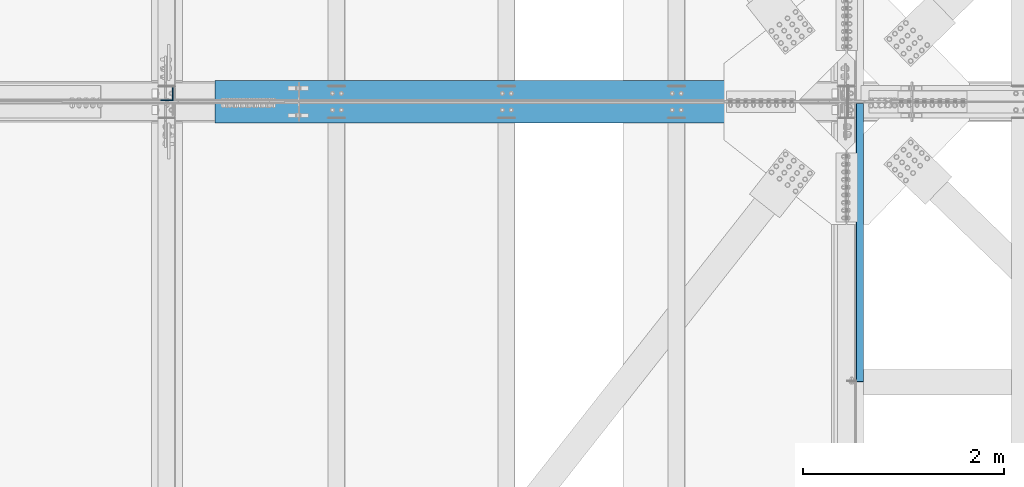
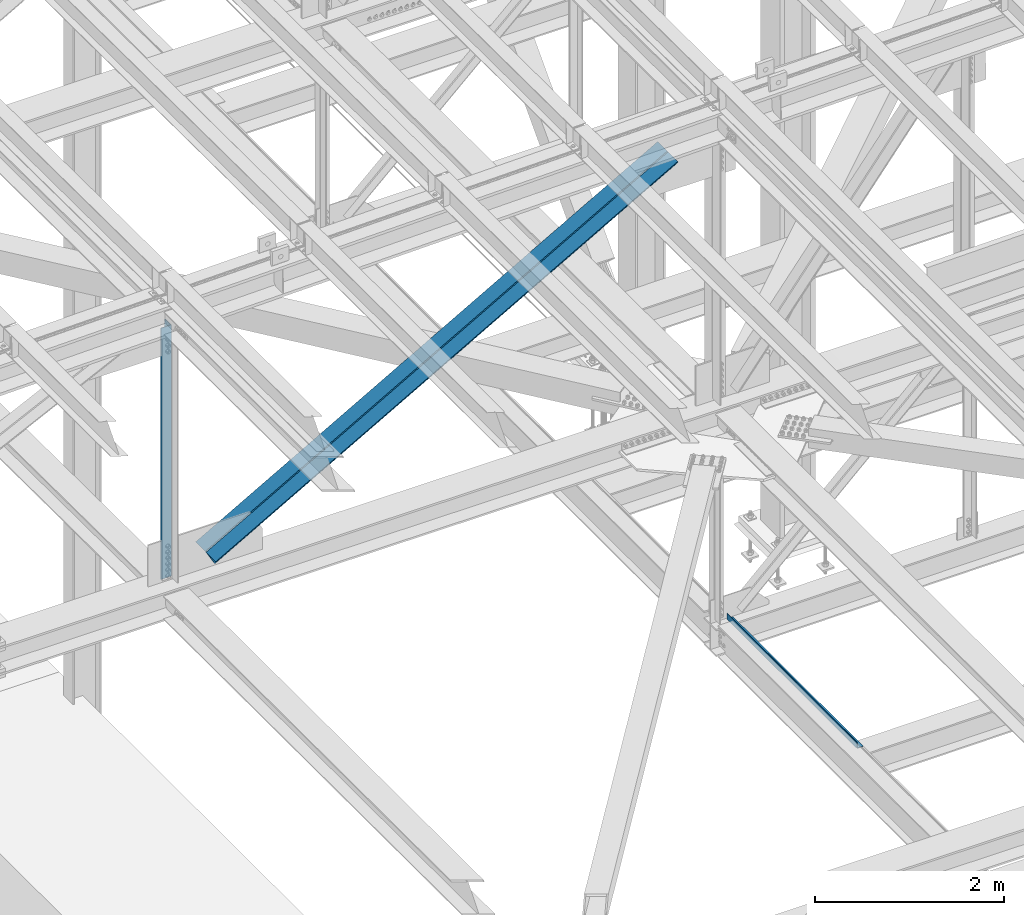
# One storey, part 1905 of 3843: 2 beams, 2 members, 4 elements without a shape of their own.
"""IFC2X3 building model written with IfcOpenShell, lengths in millimetres."""

from ifc_helpers import new_model, si_unit, frame, origin_with_axes, place, context, subcontext, project, spatial, faceted_brep, material, type_object, element, aggregate, save


model = new_model("IFC2X3")

# Units and contexts
model_context = context("Model", 3, precision=1e-05, world=origin_with_axes())
body_context = subcontext(model_context, "Body", "Model", "MODEL_VIEW")
ifc_project = project(units=[si_unit("LENGTHUNIT", "METRE", prefix="MILLI"), si_unit("AREAUNIT", "SQUARE_METRE"), si_unit("VOLUMEUNIT", "CUBIC_METRE"), si_unit("MASSUNIT", "GRAM", prefix="KILO"), si_unit("TIMEUNIT", "SECOND"), si_unit("PLANEANGLEUNIT", "RADIAN"), si_unit("SOLIDANGLEUNIT", "STERADIAN"), si_unit("THERMODYNAMICTEMPERATUREUNIT", "DEGREE_CELSIUS"), si_unit("LUMINOUSINTENSITYUNIT", "LUMEN")], contexts=[model_context])

# Site, building, storey
site_placement = place(None, origin_with_axes())
site = spatial("IfcSite", under=ifc_project, at=site_placement, CompositionType="ELEMENT")
building_placement = place(site_placement, origin_with_axes())
building = spatial("IfcBuilding", under=site, at=building_placement, Name="Undefined", CompositionType="ELEMENT")
storey_placement = place(building_placement, origin_with_axes())
storey = spatial("IfcBuildingStorey", under=building, at=storey_placement, Name="Undefined", CompositionType="ELEMENT", Elevation=0.0)

# Assembly, beam
assembly_1_placement = place(storey_placement, origin_with_axes())
assembly_1 = element("IfcElementAssembly", 1, at=assembly_1_placement, inside=storey, Name="BENT_PLATE", AssemblyPlace="NOTDEFINED", PredefinedType="RIGID_FRAME")
ifc_material_1 = material(Name="STEEL/A36")
beam_type_1 = type_object("IfcBeamType", PredefinedType="NOTDEFINED")
beam_1_placement = place(assembly_1_placement, frame((77179.4875000009, 74225.94475, 39627.1749999995), z_axis=(0.0, 1.0, 0.0), x_axis=(-1.0, 0.0, 0.0)))
beam_1 = element("IfcBeam", 2, at=beam_1_placement, type_object=beam_type_1, material=ifc_material_1, Name="BENT_PLATE", context=body_context, shape_type="Brep", body=[
    faceted_brep([(69.8500000005442, 3.17500000000291, -1379.53750006141), (73.0249999379594, 0.00100003396073589, -1382.71249999999), (0.0, 0.00100003396073589, -1382.71249999999), (0.0, 3.17500000000291, -1379.53850000001), (69.850000000617, 73.0249999994776, -1379.53750006141), (73.02500000078, 73.0249999994703, -1382.71249999999), (0.0, 3.17500000000291, 1382.71249999999), (69.8500000005442, 3.17500000000291, 1382.71249999999), (0.0, -3.17500000000291, -1382.71249999999), (0.0, -3.17500000000291, 1382.71249999999), (76.2000000005355, -3.17500000000291, -1382.71249999999), (76.2000000005355, -3.17500000000291, 1382.71249999999), (69.850000000617, 73.0249999994776, 1382.71249999999), (76.2000000006228, 73.024999999463, 1382.71249999999), (76.2000000006228, 73.024999999463, -1382.71249999999)], [[[0, 1, 2, 3]], [[4, 5, 1, 0]], [[6, 7, 0, 3]], [[8, 9, 6, 3, 2]], [[9, 8, 10, 11]], [[7, 12, 4, 0]], [[7, 6, 9, 11, 13, 12]], [[11, 10, 14, 13]], [[5, 14, 10, 8, 2, 1]], [[12, 13, 14, 5, 4]]]),
])
aggregate(assembly_1, [beam_1])

assembly_2_placement = place(storey_placement, origin_with_axes())
assembly_2 = element("IfcElementAssembly", 3, at=assembly_2_placement, inside=storey, Name="ANGLE", AssemblyPlace="NOTDEFINED", PredefinedType="RIGID_FRAME")
ifc_material_2 = material(Name="STEEL/A572-50")
beam_type_2 = type_object("IfcBeamType", Name="L5X5X3/8", PredefinedType="NOTDEFINED")
beam_2_placement = place(assembly_2_placement, frame((70256.4000000248, 75701.525, 46014.1431761409), z_axis=(-1.0, 0.0, 0.0), x_axis=(0.0, 0.0, -1.0)))
beam_2 = element("IfcBeam", 4, at=beam_2_placement, type_object=beam_type_2, material=ifc_material_2, Name="ANGLE", ObjectType="L5X5X3/8", context=body_context, shape_type="Brep", body=[
    faceted_brep([(223.220310098804, 63.5, -63.5), (223.220310098804, 63.5, 63.5), (3476.5794706795, 63.5, 63.5), (3476.5794706795, 63.5, -63.5), (223.220310098804, 53.9750000000058, 63.5), (3476.5794706795, 53.9750000000058, 63.5), (223.220310098804, 53.9750000000058, -53.9750000000058), (3476.5794706795, 53.9750000000058, -53.9750000000058), (223.220310098804, -63.5, -53.9750000000058), (3476.5794706795, -63.5, -53.9750000000058), (223.220310098804, -63.5, -63.5), (3476.5794706795, -63.5, -63.5)], [[[0, 1, 2, 3]], [[1, 4, 5, 2]], [[4, 6, 7, 5]], [[6, 8, 9, 7]], [[8, 10, 11, 9]], [[10, 0, 3, 11]], [[5, 7, 9, 11, 3, 2]], [[10, 8, 6, 4, 1, 0]]]),
])
aggregate(assembly_2, [beam_2])

# Assembly, member
assembly_3_placement = place(storey_placement, origin_with_axes())
assembly_3 = element("IfcElementAssembly", 5, at=assembly_3_placement, inside=storey, Name="ANGLE", AssemblyPlace="NOTDEFINED", PredefinedType="RIGID_FRAME")
member_type = type_object("IfcMemberType", Name="L8X8X1/2", PredefinedType="NOTDEFINED")
member_1_placement = place(assembly_3_placement, frame((77012.8000011244, 75739.625, 46150.0389029205), z_axis=(0.0, 1.0, 0.0), x_axis=(-0.870312627855801, 0.0, -0.492499674918401)))
member_1 = element("IfcMember", 6, at=member_1_placement, type_object=member_type, material=ifc_material_2, Name="ANGLE", ObjectType="L8X8X1/2", context=body_context, shape_type="Brep", body=[
    faceted_brep([(655.764717872153, 101.60000000042, -101.600000000006), (655.764717872153, 101.60000000042, 101.600000000006), (7157.46080485564, 101.600000004677, 101.600000000006), (7157.46080485564, 101.600000004677, -101.600000000006), (655.764717872153, 88.9000000004303, 101.600000000006), (7157.46080485564, 88.9000000046794, 101.600000000006), (655.764717872153, 88.9000000004303, -88.8999999999942), (7157.46080485564, 88.9000000046794, -88.8999999999942), (655.764717872138, -101.599999999555, -88.8999999999942), (7157.46080485564, -101.599999995306, -88.8999999999942), (655.764717872138, -101.599999999555, -101.600000000006), (7157.46080485564, -101.599999995306, -101.600000000006)], [[[0, 1, 2, 3]], [[1, 4, 5, 2]], [[4, 6, 7, 5]], [[6, 8, 9, 7]], [[8, 10, 11, 9]], [[10, 0, 3, 11]], [[5, 7, 9, 11, 3, 2]], [[10, 8, 6, 4, 1, 0]]]),
])
aggregate(assembly_3, [member_1])

assembly_4_placement = place(storey_placement, origin_with_axes())
assembly_4 = element("IfcElementAssembly", 7, at=assembly_4_placement, inside=storey, Name="ANGLE", AssemblyPlace="NOTDEFINED", PredefinedType="RIGID_FRAME")
member_2_placement = place(assembly_4_placement, frame((70256.4, 75517.375, 42326.6716433361), z_axis=(0.0, -1.0, 0.0), x_axis=(0.870312627855801, 0.0, 0.4924996749184)))
member_2 = element("IfcMember", 8, at=member_2_placement, type_object=member_type, material=ifc_material_2, Name="ANGLE", ObjectType="L8X8X1/2", context=body_context, shape_type="Brep", body=[
    faceted_brep([(605.726567405276, 101.599999999598, -101.600000000006), (605.726567405276, 101.599999999598, 101.600000000006), (7107.42265438878, 101.599999995335, 101.600000000006), (7107.42265438878, 101.599999995335, -101.600000000006), (605.726567405291, 88.8999999996013, 101.600000000006), (7107.42265438878, 88.8999999953376, 101.600000000006), (605.726567405291, 88.8999999996013, -88.8999999999942), (7107.42265438878, 88.8999999953376, -88.8999999999942), (605.726567405276, -101.600000000384, -88.8999999999942), (7107.42265438876, -101.600000004641, -88.8999999999942), (605.726567405276, -101.600000000384, -101.600000000006), (7107.42265438876, -101.600000004641, -101.600000000006)], [[[0, 1, 2, 3]], [[1, 4, 5, 2]], [[4, 6, 7, 5]], [[6, 8, 9, 7]], [[8, 10, 11, 9]], [[10, 0, 3, 11]], [[5, 7, 9, 11, 3, 2]], [[10, 8, 6, 4, 1, 0]]]),
])
aggregate(assembly_4, [member_2])

save(model, "model.ifc")
